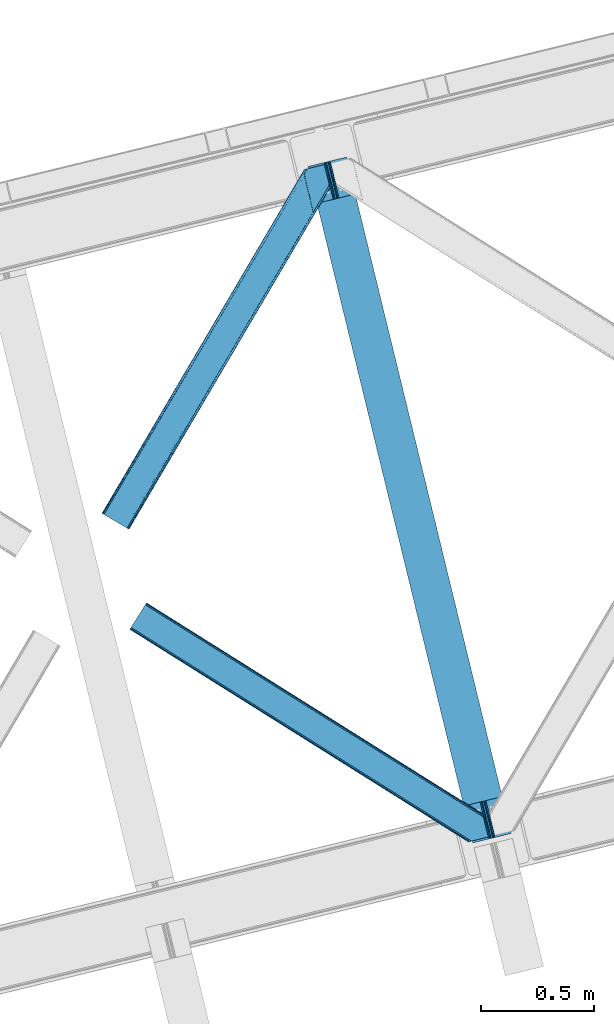
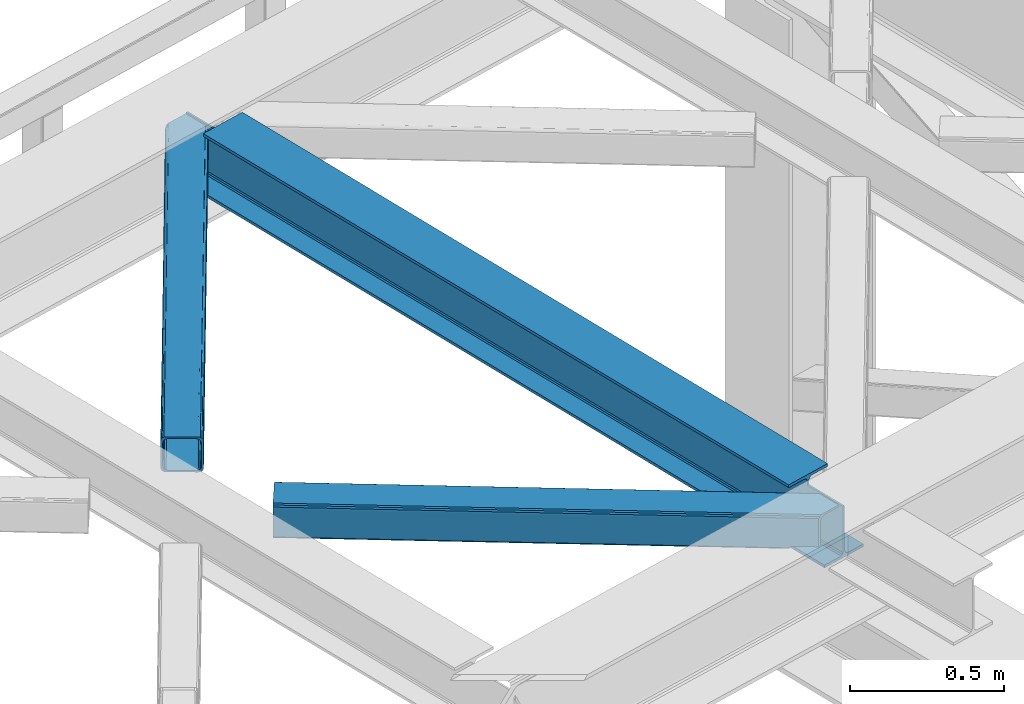
# One storey, part 26 of 92: 2 members, 1 beam.
"""IFC4 building model written with IfcOpenShell, lengths in millimetres."""

from ifc_helpers import new_model, entity, si_unit, converted_unit, derived_unit, direction, frame, origin, place, context, subcontext, project, spatial, triangles, polygons, material, type_object, element, save


model = new_model("IFC4")

# Units and contexts
model_context = context("Model", 3, precision=0.01, world=origin(), true_north=direction((6.12303176911189e-17, 1.0)))
plan_context = context("Plan", 3, precision=0.01, world=origin(), true_north=direction((6.12303176911189e-17, 1.0)))
body_context = subcontext(model_context, "Body", "Model", "MODEL_VIEW")
ifc_project = project(units=[si_unit("LENGTHUNIT", "METRE", prefix="MILLI"), si_unit("AREAUNIT", "SQUARE_METRE"), si_unit("VOLUMEUNIT", "CUBIC_METRE"), converted_unit("PLANEANGLEUNIT", "DEGREE", entity("IfcRatioMeasure", 0.0174532925199433), si_unit("PLANEANGLEUNIT", "RADIAN"), dimensions=[0, 0, 0, 0, 0, 0, 0]), si_unit("MASSUNIT", "GRAM", prefix="KILO"), derived_unit("MASSDENSITYUNIT", [(si_unit("MASSUNIT", "GRAM", prefix="KILO"), 1), (si_unit("LENGTHUNIT", "METRE"), -3)]), derived_unit("MOMENTOFINERTIAUNIT", [(si_unit("LENGTHUNIT", "METRE"), 4)]), si_unit("TIMEUNIT", "SECOND"), si_unit("FREQUENCYUNIT", "HERTZ"), si_unit("THERMODYNAMICTEMPERATUREUNIT", "DEGREE_CELSIUS"), derived_unit("THERMALTRANSMITTANCEUNIT", [(si_unit("MASSUNIT", "GRAM", prefix="KILO"), 1), (si_unit("THERMODYNAMICTEMPERATUREUNIT", "KELVIN"), -1), (si_unit("TIMEUNIT", "SECOND"), -3)]), derived_unit("VOLUMETRICFLOWRATEUNIT", [(si_unit("LENGTHUNIT", "METRE"), 3), (si_unit("TIMEUNIT", "SECOND"), -1)]), derived_unit("MASSFLOWRATEUNIT", [(si_unit("MASSUNIT", "GRAM", prefix="KILO"), 1), (si_unit("TIMEUNIT", "SECOND"), -1)]), derived_unit("ROTATIONALFREQUENCYUNIT", [(si_unit("TIMEUNIT", "SECOND"), -1)]), si_unit("ELECTRICCURRENTUNIT", "AMPERE"), si_unit("ELECTRICVOLTAGEUNIT", "VOLT"), si_unit("POWERUNIT", "WATT"), si_unit("FORCEUNIT", "NEWTON", prefix="KILO"), si_unit("ILLUMINANCEUNIT", "LUX"), si_unit("LUMINOUSFLUXUNIT", "LUMEN"), si_unit("LUMINOUSINTENSITYUNIT", "CANDELA"), derived_unit("USERDEFINED", [(si_unit("MASSUNIT", "GRAM", prefix="KILO"), -1), (si_unit("LENGTHUNIT", "METRE"), -2), (si_unit("TIMEUNIT", "SECOND"), 3), (si_unit("LUMINOUSFLUXUNIT", "LUMEN"), 1)]), derived_unit("LINEARVELOCITYUNIT", [(si_unit("LENGTHUNIT", "METRE"), 1), (si_unit("TIMEUNIT", "SECOND"), -1)]), si_unit("PRESSUREUNIT", "PASCAL"), derived_unit("USERDEFINED", [(si_unit("LENGTHUNIT", "METRE"), -2), (si_unit("MASSUNIT", "GRAM", prefix="KILO"), 1), (si_unit("TIMEUNIT", "SECOND"), -2)]), derived_unit("LINEARFORCEUNIT", [(si_unit("MASSUNIT", "GRAM", prefix="KILO"), 1), (si_unit("LENGTHUNIT", "METRE"), 1), (si_unit("TIMEUNIT", "SECOND"), -2), (si_unit("LENGTHUNIT", "METRE"), -1)]), derived_unit("PLANARFORCEUNIT", [(si_unit("MASSUNIT", "GRAM", prefix="KILO"), 1), (si_unit("LENGTHUNIT", "METRE"), 1), (si_unit("TIMEUNIT", "SECOND"), -2), (si_unit("LENGTHUNIT", "METRE"), -2)])], contexts=[model_context, plan_context])

# Site, building, storey
site_placement = place(None, origin())
site = spatial("IfcSite", under=ifc_project, at=site_placement, CompositionType="ELEMENT")
building_placement = place(site_placement, origin())
building = spatial("IfcBuilding", under=site, at=building_placement, CompositionType="ELEMENT")
storey_placement = place(building_placement, frame((0.0, 0.0, 15900.0)))
storey = spatial("IfcBuildingStorey", under=building, at=storey_placement, Name="05", CompositionType="ELEMENT", Elevation=15900.0)

# Beam
ifc_material = material(Name="Metal painted (White)")
beam_type = type_object("IfcBeamType", PredefinedType="BEAM")
beam_placement = place(storey_placement, frame((-58178.56, 3605.07, 3441.0)))
element("IfcBeam", 1, at=beam_placement, inside=storey, type_object=beam_type, material=ifc_material, ObjectType="Steel Beam", PredefinedType="BEAM", context=body_context, shape_type="Tessellation", body=[
    polygons([(900.98534618944, 41.4445662733081, 11.000000000004), (900.98534618944, 41.4445662733081, 2.16573425859679e-12), (170.021610174761, 3040.13999372697, 2.16573425859679e-12), (170.021610174761, 3040.13999372697, 11.000000000004), (834.919806235814, 25.3403919499656, 11.000000000004), (103.956070221135, 3024.03581940362, 11.000000000004), (828.971056214522, 23.8903211957396, 12.2179274798217), (98.0073201998427, 3022.5857486494, 12.2179274798217), (823.927949458413, 22.6610105689194, 15.6862915010192), (92.964213443734, 3021.35643802258, 15.6862915010192), (820.558253255237, 21.8396114687113, 20.8770650821657), (89.5945172405581, 3020.53503892237, 20.8770650821657), (819.374973305543, 21.55117446212, 27.0000000000047), (88.4112372908723, 3020.24660191578, 27.0000000000047), (81.6103728838888, 3018.58881926485, 27.0000000000047), (81.6103728838801, 3018.58881926485, 203.000000000006), (88.4112372908723, 3020.24660191578, 203.000000000006), (0.0, 2998.69542745366, 2.16573425859679e-12), (0.0, 2998.69542745366, 10.9999999999997), (66.0655399536172, 3014.799601777, 11.000000000004), (72.0142899749184, 3016.24967253123, 12.2179274798217), (77.057396731027, 3017.47898315805, 15.6862915010192), (80.4270929342029, 3018.30038225826, 20.8770650821657), (819.374973305543, 21.5511744621206, 203.000000000006), (812.574108898559, 19.8933918111876, 203.000000000006), (812.574108898559, 19.8933918111881, 27.0000000000047), (811.390828948873, 19.6049548045968, 20.8770650821657), (808.021132745689, 18.7835557043887, 15.6862915010192), (802.978025989589, 17.5542450775691, 12.2179274798217), (797.029275968296, 16.1041743233425, 11.000000000004), (730.963736014679, 0.0, 10.9999999999997), (730.963736014679, -5.41433564649196e-13, 2.16573425859679e-12), (779.675212882749, 184.415062601691, 203.069791966819), (128.020401343495, 2857.75452019162, 203.000000000006), (128.24328213265, 2856.8401777572, 203.617301946336), (128.256196377177, 2856.7871977843, 217.000003693143), (779.530009633824, 185.010597404071, 217.000003676718), (779.530880241713, 185.007025963192, 204.00000679514), (772.96491171832, 182.385463974441, 203.006342981529), (772.742064056773, 183.299815969774, 203.617301946336), (772.729149812254, 183.352795942667, 217.000003693143), (121.455336555599, 2855.1293963229, 217.000003676718), (121.45446594771, 2855.13296776378, 204.00000679514), (121.310166358664, 2855.72494066435, 203.076120467494), (121.219536936511, 2856.09673754069, 203.000000000006), (780.71349435786, 185.298194377514, 223.122939328039), (784.082490766539, 186.122464201394, 228.313710402595), (789.125126170554, 187.353708426698, 231.782072735464), (795.073705041275, 188.80448128138, 232.999999602236), (861.139155906781, 204.909021065314, 232.999999283132), (861.137682570343, 204.915065042188, 243.999994005812), (691.116301666431, 163.469558245297, 243.999994827032), (691.117775002877, 163.463514268424, 233.000000104353), (757.183225868401, 179.568054052359, 232.999999785253), (763.132130996731, 181.017488520582, 231.782072861016), (768.17569550387, 182.244921343718, 228.313710479427), (771.546082413602, 183.063487001147, 223.12293937232), (120.271851831572, 2854.84179934945, 223.122939328039), (116.902855422893, 2854.01752952557, 228.313710402595), (111.860220018869, 2852.78628530027, 231.782072735464), (105.911641148174, 2851.33551244559, 232.999999602236), (39.8461902826505, 2835.23097266165, 232.999999283128), (39.8476636190881, 2835.22492868478, 243.999994005812), (209.869044522992, 2876.67043548167, 243.999994827032), (209.867571186554, 2876.67647945854, 233.000000104357), (143.802120321031, 2860.57193967461, 232.999999785253), (137.85321519271, 2859.12250520639, 231.782072861012), (132.809650685579, 2857.89507238325, 228.313710479427), (129.439263775838, 2857.07650672582, 223.12293937232)], [[[1, 2, 3, 4]], [[5, 1, 4, 6]], [[7, 5, 6, 8]], [[9, 7, 8, 10]], [[11, 9, 10, 12]], [[13, 11, 12, 14]], [[15, 16, 17, 14, 12, 10, 8, 6, 4, 3, 18, 19, 20, 21, 22, 23]], [[13, 24, 25, 26, 27, 28, 29, 30, 31, 32, 2, 1, 5, 7, 9, 11]], [[2, 32, 18, 3]], [[32, 31, 19, 18]], [[31, 30, 20, 19]], [[27, 26, 15, 23]], [[28, 27, 23, 22]], [[29, 28, 22, 21]], [[30, 29, 21, 20]], [[33, 24, 13, 14, 17, 34, 35, 36, 37, 38]], [[25, 39, 40, 41, 42, 43, 44, 16, 15, 26]], [[39, 25, 24, 33]], [[45, 34, 17, 16]], [[41, 40, 38, 37, 46, 47, 48, 49, 50, 51, 52, 53, 54, 55, 56, 57]], [[42, 58, 59, 60, 61, 62, 63, 64, 65, 66, 67, 68, 69, 36, 35, 43]], [[46, 37, 36, 69]], [[47, 46, 69, 68]], [[48, 47, 68, 67]], [[49, 48, 67, 66]], [[50, 49, 66, 65]], [[51, 50, 65, 64]], [[52, 51, 64, 63]], [[53, 52, 63, 62]], [[54, 53, 62, 61]], [[55, 54, 61, 60]], [[56, 55, 60, 59]], [[57, 56, 59, 58]], [[41, 57, 58, 42]]], closed=False),
])

# Members
member_type_1 = type_object("IfcMemberType", PredefinedType="BRACE")
member_1_placement = place(storey_placement, frame((-59092.24, 4994.99, 3511.0)))
element("IfcMember", 2, at=member_1_placement, inside=storey, type_object=member_type_1, ObjectType="Steel Horizontal Brace", PredefinedType="BRACE", context=body_context, shape_type="Tessellation", body=[
    triangles([(105.565649414064, 8.87794647216742, 0.0), (15.0828002929702, 62.1479507446284, 0.0), (892.847827148435, 1346.1393447876, 0.0), (857.170935058595, 1492.50250396728, 0.0), (854.896655273435, 1501.83739929199, 1.33247680664135), (9.31105957031104, 65.5459991455073, 1.33247680664135), (852.966540527341, 1509.75145111084, 5.12526855468968), (4.4183349609375, 68.4260559082031, 5.12526855468968), (851.678247070311, 1515.03950042725, 10.8028289794929), (1.14876708984229, 70.3509384155268, 10.8028289794929), (851.222460937497, 1516.89636383057, 17.5000946044929), (0.0, 71.0264785766603, 17.5000946044929), (893.638476562497, 1342.89768218994, 0.155804443362285), (111.337390136716, 5.48047943115216, 1.33247680664135), (899.559045410155, 1344.34119873047, 1.33247680664135), (912.390820312503, 1347.46949615478, 10.8028289794929), (914.195361328122, 1347.90958557129, 17.5000946044929), (120.643798828125, 0.0, 17.5000946044929), (119.499682617185, 0.675540161132631, 10.8028289794929), (907.251599121097, 1346.21666564941, 5.12526855468968), (116.230114746089, 2.59984130859357, 5.12526855468968), (902.498400878903, 1345.05743408203, 17.9802978515654), (893.638476562497, 1342.89768218994, 9.69243164062573), (897.768457031249, 1343.90459747314, 12.1260040283232), (903.726232910158, 1345.35625305176, 19.4999725341804), (914.195361328122, 1347.90958557129, 19.4999725341804), (1011.61732177735, 1513.38611297607, 19.4999725341804), (1008.98957519532, 1524.16103668213, 19.4999725341804), (1011.61732177735, 1513.38611297607, 122.500662231447), (120.643798828125, 0.0, 122.500662231447), (114.61160888672, 3.55094604492206, 24.4996673583992), (1009.24072265625, 1523.14365692139, 24.4996673583992), (113.46749267578, 4.22706756591742, 17.8035644531265), (110.197924804685, 6.15136871337836, 12.1260040283232), (105.305200195311, 9.03200683593695, 8.3320495605476), (99.5334594726519, 12.4294738769531, 6.99957275390625), (892.685046386716, 1346.79976959229, 8.88434143066479), (890.471228027345, 1355.89688873291, 6.99957275390625), (21.114990234375, 58.5970046997072, 6.99957275390625), (859.547534179685, 1482.74496002197, 6.99957275390625), (853.961828613283, 1505.65984039307, 18.5000335693367), (851.222460937497, 1516.89636383057, 18.5000335693367), (854.096704101561, 1505.10871124268, 17.8803039550803), (855.343139648438, 1499.99390716553, 12.1260040283232), (857.273254394531, 1492.07985534668, 8.3320495605476), (1009.24072265625, 1523.14365692139, 115.501089477541), (114.61160888672, 3.55094604492206, 115.501089477541), (1008.78493652344, 1525.00052032471, 122.196029663086), (113.46749267578, 4.22706756591742, 122.196029663086), (1007.49664306641, 1530.28856964111, 127.87475280762), (110.197924804685, 6.15136871337836, 127.87475280762), (1005.57117919922, 1538.20262145996, 131.667544555665), (105.305200195311, 9.03200683593695, 131.667544555665), (1003.29224853516, 1547.53751678467, 133.000021362306), (99.5334594726519, 12.4294738769531, 133.000021362306), (851.952648925784, 1518.13291625977, 19.4999725341804), (854.580395507815, 1507.35799255371, 19.4999725341804), (851.780566406247, 1517.83991088867, 19.2639404296897), (854.43156738281, 1506.94987792969, 19.2592895507842), (851.589880371095, 1517.51434936523, 19.0000030517585), (854.268786621091, 1506.50920715332, 19.0000030517585), (851.394543457034, 1517.1887878418, 18.736065673831), (854.110656738281, 1506.06795501709, 18.7407165527366), (908.014343261719, 1598.12628936768, 19.4999725341804), (897.545214843747, 1595.57353820801, 19.4999725341804), (1011.16618652343, 1515.24297637939, 129.197927856447), (1009.8778930664, 1520.53160705566, 134.874325561526), (1008.43146972657, 1526.45624542236, 137.999716186525), (986.311889648438, 1617.21117095947, 137.999716186525), (986.311889648438, 1617.21117095947, 133.000021362306), (897.545214843747, 1595.57353820801, 122.500662231447), (0.0, 71.0264785766603, 122.500662231447), (7.18095703124709, 66.799411010742, 17.8035644531265), (10.4505249023423, 64.8751098632811, 12.1260040283232), (6.03218994140479, 67.4755325317383, 24.4996673583992), (907.028356933595, 1597.88560638428, 24.4996673583992), (15.3432495117158, 61.9944717407225, 8.3320495605476), (908.832897949222, 1598.32511444092, 122.196029663086), (899.349755859374, 1596.01362762451, 129.197927856447), (904.48897705078, 1597.26645812988, 134.874325561526), (930.738537597659, 1603.66490478516, 133.000021362306), (910.246765136719, 1598.66986083984, 137.999716186525), (921.664672851563, 1601.45341186523, 131.667544555665), (913.972119140628, 1599.57794494629, 127.87475280762), (907.028356933595, 1597.88560638428, 115.501089477541), (21.114990234375, 58.5970046997072, 133.000021362306), (6.03218994140479, 67.4755325317383, 115.501089477541), (15.3432495117158, 61.9944717407225, 131.667544555665), (10.4505249023423, 64.8751098632811, 127.87475280762), (7.18095703124709, 66.799411010742, 122.196029663086), (119.499682617185, 0.675540161132631, 129.197927856447), (116.230114746089, 2.59984130859357, 134.874325561526), (111.337390136716, 5.48047943115216, 138.667117309571), (105.565649414064, 8.87794647216742, 139.999594116212), (15.0828002929702, 62.1479507446284, 139.999594116212), (9.31105957031104, 65.5459991455073, 138.667117309571), (4.4183349609375, 68.4260559082031, 134.874325561526), (1.14876708984229, 70.3509384155268, 129.197927856447), (896.991760253906, 1576.15553741455, 137.999716186525), (938.18924560547, 1407.14434204102, 137.999716186525), (899.024194335936, 1563.5946762085, 139.999594116212), (897.042919921878, 1571.72266845703, 138.999655151369), (896.801074218747, 1573.13653564453, 138.639212036134), (896.926647949222, 1575.15443572998, 138.211331176761), (896.86153564453, 1574.14112548828, 138.427597045898), (937.477661132813, 1407.08562469482, 138.29272155762), (937.077685546872, 1408.09486541748, 138.646188354494), (936.682360839841, 1409.10410614014, 138.999655151369), (934.701086425783, 1417.23209838867, 139.999594116212)], [[1, 2, 3], [4, 3, 2], [5, 4, 6], [2, 6, 4], [7, 5, 8], [6, 8, 5], [9, 7, 10], [8, 10, 7], [11, 9, 12], [10, 12, 9], [1, 3, 13], [13, 14, 1], [13, 15, 14], [16, 17, 18], [18, 19, 16], [20, 16, 19], [19, 21, 20], [15, 20, 21], [21, 14, 15], [20, 22, 16], [23, 24, 15], [23, 15, 13], [15, 24, 20], [16, 25, 17], [20, 24, 22], [16, 22, 25], [26, 17, 25], [26, 25, 27], [28, 27, 25], [27, 29, 26], [30, 26, 29], [26, 18, 17], [30, 18, 26], [31, 32, 25], [25, 33, 31], [25, 22, 33], [32, 28, 25], [33, 22, 24], [34, 24, 23], [23, 35, 34], [36, 35, 37], [37, 38, 36], [23, 37, 35], [24, 34, 33], [39, 36, 38], [38, 40, 39], [9, 11, 41], [11, 42, 41], [43, 9, 41], [43, 7, 9], [44, 7, 43], [5, 44, 45], [44, 5, 7], [4, 5, 45], [45, 40, 4], [37, 23, 13], [37, 3, 38], [3, 40, 38], [40, 3, 4], [37, 13, 3], [46, 32, 31], [31, 47, 46], [48, 46, 49], [47, 49, 46], [50, 48, 51], [49, 51, 48], [52, 50, 53], [51, 53, 50], [54, 52, 55], [53, 55, 52], [56, 57, 58], [59, 58, 57], [58, 59, 60], [61, 60, 59], [60, 61, 62], [63, 62, 61], [62, 63, 42], [41, 42, 63], [57, 56, 64], [65, 64, 56], [66, 48, 67], [46, 29, 27], [27, 32, 46], [32, 27, 28], [48, 29, 46], [66, 29, 48], [50, 68, 67], [52, 68, 50], [67, 48, 50], [52, 54, 68], [54, 69, 68], [70, 69, 54], [71, 60, 62], [58, 60, 71], [71, 56, 58], [56, 71, 65], [42, 12, 72], [12, 42, 11], [71, 42, 72], [42, 71, 62], [73, 74, 44], [75, 73, 43], [43, 41, 75], [43, 57, 75], [64, 76, 57], [75, 57, 76], [44, 43, 73], [45, 44, 74], [74, 77, 45], [40, 45, 77], [77, 39, 40], [78, 79, 80], [81, 82, 69], [69, 70, 81], [81, 83, 82], [84, 82, 83], [80, 82, 84], [78, 71, 79], [85, 71, 78], [80, 84, 78], [65, 76, 64], [85, 65, 71], [76, 65, 85], [86, 54, 55], [54, 86, 81], [70, 54, 81], [76, 85, 75], [87, 75, 85], [83, 81, 86], [86, 88, 83], [84, 83, 88], [88, 89, 84], [78, 84, 89], [89, 90, 78], [85, 78, 90], [90, 87, 85], [91, 51, 49], [47, 18, 30], [91, 49, 30], [91, 92, 51], [49, 47, 30], [51, 92, 93], [55, 94, 95], [94, 53, 93], [53, 94, 55], [53, 51, 93], [19, 34, 21], [31, 18, 47], [18, 33, 19], [33, 18, 31], [19, 33, 34], [1, 36, 2], [14, 21, 34], [34, 35, 14], [35, 36, 1], [1, 14, 35], [89, 96, 97], [95, 86, 55], [95, 88, 86], [88, 95, 96], [89, 88, 96], [87, 72, 12], [98, 90, 89], [97, 98, 89], [90, 98, 72], [87, 90, 72], [6, 74, 8], [2, 36, 39], [39, 77, 2], [77, 74, 6], [6, 2, 77], [10, 8, 74], [12, 75, 87], [73, 12, 10], [12, 73, 75], [73, 10, 74], [99, 68, 82], [99, 100, 68], [68, 69, 82], [96, 95, 101], [101, 102, 96], [97, 96, 103], [104, 97, 105], [104, 99, 97], [97, 103, 105], [82, 80, 99], [97, 99, 80], [102, 103, 96], [79, 71, 98], [72, 98, 71], [80, 79, 97], [98, 97, 79], [92, 67, 100], [100, 93, 92], [67, 68, 100], [106, 107, 93], [94, 93, 107], [107, 108, 94], [108, 109, 94], [66, 67, 92], [92, 91, 66], [29, 66, 91], [91, 30, 29], [95, 94, 109], [109, 101, 95], [107, 103, 102], [105, 103, 107], [106, 104, 105], [100, 99, 104], [107, 106, 105], [102, 108, 107], [102, 101, 109], [109, 108, 102]]),
])
member_type_2 = type_object("IfcMemberType", PredefinedType="BRACE")
member_2_placement = place(storey_placement, frame((-58968.51, 3609.34, 3511.0)))
element("IfcMember", 3, at=member_2_placement, inside=storey, type_object=member_type_2, ObjectType="Steel Horizontal Brace", PredefinedType="BRACE", context=body_context, shape_type="Tessellation", body=[
    triangles([(9.3017578125, 956.602365875244, 0.0), (65.121606445311, 1045.53560028076, 0.0), (1381.50172119141, 219.293009948731, 0.0), (1417.17861328126, 72.9304321289064, 0.0), (1422.67130126953, 50.3934356689456, 10.8028289794929), (1423.12708740235, 48.5365722656252, 17.5000946044929), (0.0, 941.780014801026, 17.5000946044929), (0.706933593748545, 942.908434295654, 10.8028289794929), (1421.3830078125, 55.6811943054204, 5.12526855468968), (2.72076416015625, 946.121319580079, 5.12526855468968), (1419.45289306641, 63.5952461242678, 1.33247680664135), (5.73918457031687, 950.930037689209, 1.33247680664135), (68.6795288085923, 1051.20763778687, 1.33247680664135), (71.6979492187529, 1056.016355896, 5.12526855468968), (1377.30662841797, 236.497192382813, 5.17061462402489), (73.7164306640625, 1059.22924118042, 10.8028289794929), (1382.10168457031, 238.005530548096, 10.8028289794929), (1383.90622558594, 238.4456199646, 17.5000946044929), (74.423364257811, 1060.35766067505, 17.5000946044929), (1379.22744140626, 228.628195953369, 1.33247680664135), (1377.23221435547, 236.818103027344, 17.5198608398459), (1383.90622558594, 238.4456199646, 18.5197998046897), (1378.19959716797, 237.055007171631, 18.5197998046897), (1379.50649414063, 231.698357391358, 18.5197998046897), (1563.91384277344, 125.462400054932, 18.5197998046897), (1566.64855957031, 114.236631774902, 18.5197998046897), (1563.91384277344, 125.462400054932, 122.500662231447), (74.423364257811, 1060.35766067505, 122.500662231447), (1564.36497802735, 123.605536651612, 129.197927856447), (73.7164306640625, 1059.22924118042, 129.197927856447), (1565.65327148438, 118.317487335205, 134.874325561526), (71.6979492187529, 1056.016355896, 134.874325561526), (1567.58338623047, 110.403726196289, 138.667117309571), (68.6795288085923, 1051.20763778687, 138.667117309571), (1569.85766601563, 101.068540191651, 139.999594116212), (65.121606445311, 1045.53560028076, 139.999594116212), (67.9772460937529, 1050.08735733032, 12.1260040283232), (1379.67392578125, 226.784703826905, 12.1260040283232), (1378.42749023438, 231.905030822754, 17.5198608398459), (69.9957275390625, 1053.30053329468, 17.8035644531265), (1566.29044189453, 115.704856109619, 24.4996673583992), (70.702661132811, 1054.42895278931, 24.4996673583992), (1381.60404052735, 218.870652008057, 8.3320495605476), (64.9588256835923, 1045.27892990112, 8.3320495605476), (1383.87832031251, 209.535466003418, 6.99957275390625), (61.400903320311, 1039.60660171509, 6.99957275390625), (13.0224609375, 962.531073760987, 6.99957275390625), (1414.80201416016, 82.6876853942872, 6.99957275390625), (1419.00640869141, 65.4387382507325, 12.1260040283232), (1420.25284423828, 60.3181205749515, 17.5198608398459), (1417.07629394531, 73.3527900695804, 8.3320495605476), (1566.29044189453, 115.704856109619, 115.501089477541), (70.702661132811, 1054.42895278931, 115.501089477541), (1569.95998535157, 100.646182250977, 131.667544555665), (1572.23891601563, 91.3109962463382, 133.000021362306), (61.400903320311, 1039.60660171509, 133.000021362306), (64.9588256835923, 1045.27892990112, 131.667544555665), (1568.03452148438, 108.559943389893, 127.87475280762), (67.9772460937529, 1050.08735733032, 127.87475280762), (1566.74622802735, 113.847992706299, 122.196029663086), (69.9957275390625, 1053.30053329468, 122.196029663086), (1589.21927490235, 21.6376327514649, 133.000021362306), (1589.21927490235, 21.6376327514649, 139.999594116212), (9.3017578125, 956.602365875244, 139.999594116212), (1524.16743164063, 5.77958908081064, 139.999594116212), (1515.09356689453, 3.5678054809573, 138.667117309571), (5.73918457031687, 950.930037689209, 138.667117309571), (1507.4010131836, 1.69262924194345, 134.874325561526), (2.72076416015625, 946.121319580079, 134.874325561526), (1502.26179199219, 0.439798736572357, 129.197927856447), (0.706933593748545, 942.908434295654, 129.197927856447), (1500.45725097656, 0.0, 122.500662231447), (0.0, 941.780014801026, 122.500662231447), (1424.34096679688, 47.7738281250004, 18.5197998046897), (1500.45725097656, 0.0, 18.5197998046897), (1421.60625, 58.9995964050295, 18.5197998046897), (1511.36821289063, 2.65972137451172, 18.5197998046897), (3.720703125, 947.708722686767, 24.4996673583992), (1509.94039306641, 2.31177749633798, 24.4996673583992), (4.42763671874854, 948.837142181397, 17.8035644531265), (1420.92722167969, 59.6588584899905, 18.0198303222678), (6.44611816406541, 952.050318145752, 12.1260040283232), (9.45988769531687, 956.858745574952, 8.3320495605476), (6.44611816406541, 952.050318145752, 127.87475280762), (13.0224609375, 962.531073760987, 133.000021362306), (9.45988769531687, 956.858745574952, 131.667544555665), (3.720703125, 947.708722686767, 115.501089477541), (4.42763671874854, 948.837142181397, 122.196029663086), (1524.57670898438, 5.87958297729529, 131.667544555665), (1516.88415527344, 4.00440673828143, 127.87475280762), (1511.74493408203, 2.75157623291034, 122.196029663086), (1533.65057373047, 8.09136657714862, 133.000021362306), (1509.94039306641, 2.31177749633798, 115.501089477541)], [[1, 2, 3], [3, 4, 1], [5, 6, 7], [7, 8, 5], [9, 5, 8], [8, 10, 9], [11, 9, 10], [10, 12, 11], [4, 11, 12], [12, 1, 4], [13, 14, 15], [16, 17, 15], [15, 14, 16], [18, 17, 19], [16, 19, 17], [20, 3, 2], [2, 13, 20], [15, 20, 13], [18, 21, 17], [18, 22, 23], [17, 21, 15], [21, 18, 23], [24, 22, 25], [22, 24, 23], [25, 26, 24], [25, 22, 27], [19, 22, 18], [22, 28, 27], [19, 28, 22], [29, 27, 30], [28, 30, 27], [31, 29, 32], [30, 32, 29], [33, 31, 34], [32, 34, 31], [35, 33, 36], [34, 36, 33], [37, 38, 39], [39, 40, 37], [24, 41, 42], [24, 26, 41], [42, 40, 39], [43, 38, 44], [37, 44, 38], [45, 43, 46], [44, 46, 43], [46, 47, 45], [48, 45, 47], [3, 48, 4], [43, 20, 38], [39, 15, 21], [15, 39, 38], [38, 20, 15], [43, 3, 20], [3, 45, 48], [43, 45, 3], [9, 49, 50], [50, 5, 9], [6, 5, 50], [49, 11, 51], [51, 4, 48], [4, 51, 11], [49, 9, 11], [41, 52, 53], [53, 42, 41], [54, 55, 56], [56, 57, 54], [58, 54, 57], [57, 59, 58], [60, 58, 59], [59, 61, 60], [52, 60, 61], [61, 53, 52], [58, 31, 33], [58, 33, 54], [55, 54, 35], [60, 31, 58], [62, 55, 63], [35, 63, 55], [54, 33, 35], [29, 31, 60], [25, 27, 52], [41, 25, 52], [25, 41, 26], [29, 60, 27], [60, 52, 27], [64, 35, 36], [35, 64, 65], [63, 35, 65], [66, 65, 64], [64, 67, 66], [68, 66, 67], [67, 69, 68], [70, 68, 69], [69, 71, 70], [72, 70, 71], [71, 73, 72], [74, 72, 6], [74, 75, 72], [73, 6, 72], [73, 7, 6], [74, 76, 77], [77, 75, 74], [78, 79, 76], [76, 80, 78], [76, 81, 80], [79, 77, 76], [50, 82, 80], [50, 49, 82], [51, 48, 83], [47, 83, 48], [49, 51, 82], [83, 82, 51], [16, 37, 40], [42, 28, 19], [16, 40, 19], [16, 14, 37], [40, 42, 19], [37, 14, 13], [46, 2, 1], [2, 44, 13], [44, 2, 46], [44, 37, 13], [30, 59, 32], [53, 28, 42], [28, 61, 30], [61, 28, 53], [30, 61, 59], [36, 56, 64], [34, 32, 59], [59, 57, 34], [57, 56, 36], [36, 34, 57], [82, 12, 10], [1, 47, 46], [1, 83, 47], [83, 1, 12], [82, 83, 12], [78, 7, 73], [8, 80, 82], [10, 8, 82], [80, 8, 7], [78, 80, 7], [67, 84, 69], [64, 56, 85], [85, 86, 64], [86, 84, 67], [67, 64, 86], [71, 69, 84], [73, 87, 78], [88, 73, 71], [73, 88, 87], [88, 71, 84], [89, 65, 66], [90, 66, 68], [91, 68, 70], [92, 63, 65], [89, 66, 90], [62, 63, 92], [89, 92, 65], [91, 90, 68], [72, 93, 91], [93, 72, 75], [79, 75, 77], [75, 79, 93], [72, 91, 70], [85, 55, 92], [85, 56, 55], [55, 62, 92], [91, 93, 88], [87, 88, 93], [90, 91, 84], [88, 84, 91], [89, 90, 86], [84, 86, 90], [92, 89, 85], [86, 85, 89], [93, 79, 78], [78, 87, 93]]),
])

save(model, "model.ifc")
